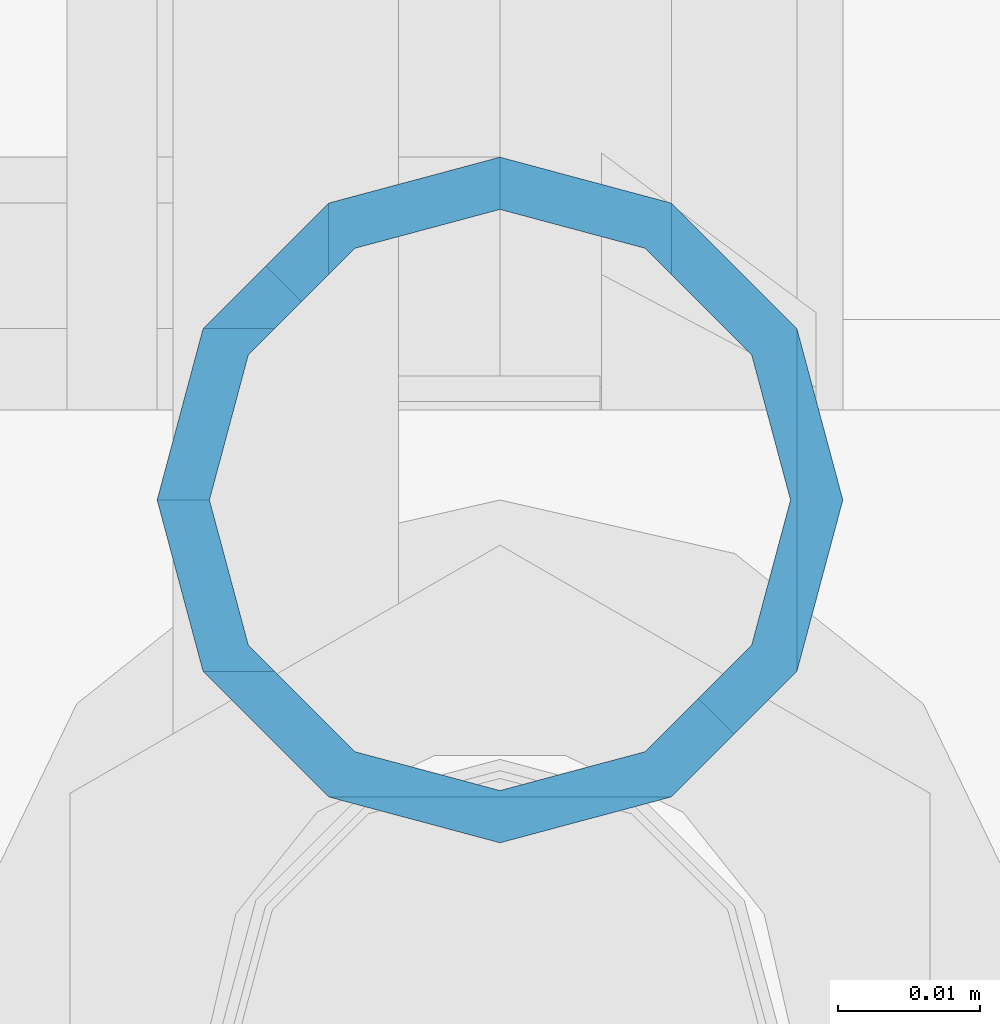
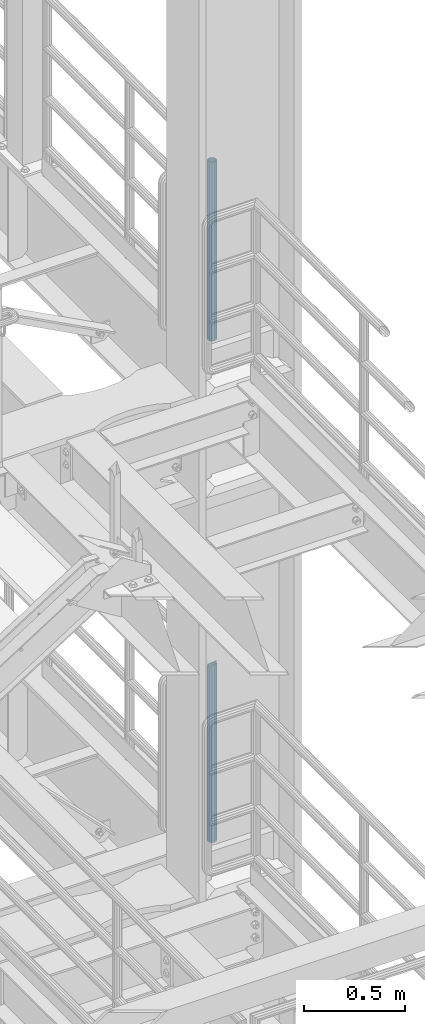
# One storey, part 663 of 1876: 2 columns, 2 elements without a shape of their own.
"""IFC2X3 building model written with IfcOpenShell, lengths in millimetres."""

from ifc_helpers import new_model, si_unit, frame, origin_with_axes, place, context, subcontext, project, spatial, faceted_brep, material, type_object, element, aggregate, save


model = new_model("IFC2X3")

# Units and contexts
model_context = context("Model", 3, precision=1e-05, world=origin_with_axes())
body_context = subcontext(model_context, "Body", "Model", "MODEL_VIEW")
ifc_project = project(units=[si_unit("LENGTHUNIT", "METRE", prefix="MILLI"), si_unit("AREAUNIT", "SQUARE_METRE"), si_unit("VOLUMEUNIT", "CUBIC_METRE"), si_unit("MASSUNIT", "GRAM", prefix="KILO"), si_unit("TIMEUNIT", "SECOND"), si_unit("PLANEANGLEUNIT", "RADIAN"), si_unit("SOLIDANGLEUNIT", "STERADIAN"), si_unit("THERMODYNAMICTEMPERATUREUNIT", "DEGREE_CELSIUS"), si_unit("LUMINOUSINTENSITYUNIT", "LUMEN")], contexts=[model_context])

# Site, building, storey
site_placement = place(None, origin_with_axes())
site = spatial("IfcSite", under=ifc_project, at=site_placement, CompositionType="ELEMENT")
building_placement = place(site_placement, origin_with_axes())
building = spatial("IfcBuilding", under=site, at=building_placement, Name="Undefined", CompositionType="ELEMENT")
storey_placement = place(building_placement, origin_with_axes())
storey = spatial("IfcBuildingStorey", under=building, at=storey_placement, Name="Undefined", CompositionType="ELEMENT", Elevation=0.0)

# Assembly, column
assembly_1_placement = place(storey_placement, origin_with_axes())
assembly_1 = element("IfcElementAssembly", 1, at=assembly_1_placement, inside=storey, Name="RAIL", AssemblyPlace="NOTDEFINED", PredefinedType="RIGID_FRAME")
ifc_material = material()
column_type = type_object("IfcColumnType", Name="PIPE1-1/2SCH40", PredefinedType="NOTDEFINED")
column_1_placement = place(assembly_1_placement, frame((7620.0, -4356.1, 8153.4), z_axis=(0.0, 1.0, 0.0), x_axis=(0.0, 0.0, 1.0)))
column_1 = element("IfcColumn", 2, at=column_1_placement, type_object=column_type, material=ifc_material, Name="POST", ObjectType="PIPE1-1/2SCH40", context=body_context, shape_type="Brep", body=[
    faceted_brep([(0.0, -20.4469999999999, 0.0), (0.0, -17.7076214311803, 10.2235000000001), (1076.325, -17.7076214311801, 10.2235000000001), (1076.325, -20.4469999999999, 0.0), (0.0, -10.2235000000001, 17.7076214311801), (1076.325, -10.2235000000001, 17.7076214311801), (-1.45519152283669e-11, 0.0, 20.4470000000001), (1076.325, 0.0, 20.4470000000001), (0.0, 10.2235000000001, 17.7076214311801), (1076.325, 10.2235000000001, 17.7076214311801), (0.0, 17.7076214311803, 10.2235000000001), (1076.325, 17.7076214311801, 10.2235000000001), (0.0, 20.4469999999999, 0.0), (1076.325, 20.4469999999999, 0.0), (0.0, 17.7076214311803, -10.2235000000001), (1076.325, 17.7076214311801, -10.2235000000001), (0.0, 10.2235000000001, -17.7076214311801), (1076.325, 10.2235000000001, -17.7076214311801), (-1.45519152283669e-11, 0.0, -20.4470000000001), (1076.325, 0.0, -20.4470000000001), (0.0, -10.2235000000001, -17.7076214311801), (1076.325, -10.2235000000001, -17.7076214311801), (0.0, -17.7076214311803, -10.2235000000001), (1076.325, -17.7076214311801, -10.2235000000001), (0.0, -24.1299999999992, 0.0), (0.0, -20.8971929933184, -12.0649999999996), (1076.325, -20.8971929933186, -12.0649999999996), (1076.325, -24.1300000000001, 0.0), (0.0, -12.0650000000001, -20.8971929933186), (1076.325, -12.0649999999996, -20.8971929933186), (-1.45519152283669e-11, 0.0, -24.130000000001), (1076.325, 0.0, -24.1300000000001), (0.0, 12.0650000000001, -20.8971929933186), (1076.325, 12.0649999999996, -20.8971929933186), (0.0, 20.8971929933184, -12.0649999999996), (1076.325, 20.8971929933186, -12.0649999999996), (0.0, 24.1299999999992, 0.0), (1076.325, 24.1300000000001, 0.0), (0.0, 20.8971929933184, 12.0649999999996), (1076.325, 20.8971929933186, 12.0649999999996), (0.0, 12.0650000000001, 20.8971929933186), (1076.325, 12.0649999999996, 20.8971929933186), (-1.45519152283669e-11, 0.0, 24.130000000001), (1076.325, 0.0, 24.1300000000001), (0.0, -12.0650000000001, 20.8971929933186), (1076.325, -12.0649999999996, 20.8971929933186), (0.0, -20.8971929933184, 12.0649999999996), (1076.325, -20.8971929933186, 12.0649999999996)], [[[0, 1, 2, 3]], [[1, 4, 5, 2]], [[4, 6, 7, 5]], [[6, 8, 9, 7]], [[8, 10, 11, 9]], [[10, 12, 13, 11]], [[12, 14, 15, 13]], [[14, 16, 17, 15]], [[16, 18, 19, 17]], [[18, 20, 21, 19]], [[20, 22, 23, 21]], [[22, 0, 3, 23]], [[24, 25, 26, 27]], [[25, 28, 29, 26]], [[28, 30, 31, 29]], [[30, 32, 33, 31]], [[32, 34, 35, 33]], [[34, 36, 37, 35]], [[36, 38, 39, 37]], [[38, 40, 41, 39]], [[40, 42, 43, 41]], [[42, 44, 45, 43]], [[44, 46, 47, 45]], [[46, 24, 27, 47]], [[29, 31, 33, 35, 37, 39, 41, 43, 45, 47, 27, 26], [5, 7, 9, 11, 13, 15, 17, 19, 21, 23, 3, 2]], [[46, 44, 42, 40, 38, 36, 34, 32, 30, 28, 25, 24], [22, 20, 18, 16, 14, 12, 10, 8, 6, 4, 1, 0]]]),
])
aggregate(assembly_1, [column_1])

assembly_2_placement = place(storey_placement, origin_with_axes())
assembly_2 = element("IfcElementAssembly", 3, at=assembly_2_placement, inside=storey, Name="RAIL", AssemblyPlace="NOTDEFINED", PredefinedType="RIGID_FRAME")
column_2_placement = place(assembly_2_placement, frame((7620.0, -4356.10000000001, 5130.8), z_axis=(0.0, 1.0, 0.0), x_axis=(0.0, 0.0, 1.0)))
column_2 = element("IfcColumn", 4, at=column_2_placement, type_object=column_type, material=ifc_material, Name="POST", ObjectType="PIPE1-1/2SCH40", context=body_context, shape_type="Brep", body=[
    faceted_brep([(1076.325, 0.0, -24.1300000000001), (1064.26, 12.065, -20.8971929933186), (1064.26, -12.0650000000001, -20.8971929933186), (1059.84389372908, 16.4810867391852, -16.481106254133), (1057.32835795174, 13.9655509593595, -13.9655704718216), (1061.07042843786, 10.2235000000001, -17.7076214311801), (1063.80980700668, 0.0, -20.4470000000001), (1061.07042843786, -10.2235000000001, -17.7076214311801), (1055.42780700668, -15.8661214311742, -12.065000000006), (1055.42780700668, -20.8971929933184, -12.0649999999996), (1054.93437856882, -17.7076214311801, -10.2235000000001), (1052.195, -20.4470000000001, 0.0), (1052.195, -24.1300000000001, 0.0), (1054.93437856882, -17.7076214311801, 10.2235000000001), (1055.42780700668, -15.8661214311869, 12.0649999999932), (1055.42780700668, -20.8971929933184, 12.0649999999996), (1057.32837749183, -13.9655704718189, 13.9655509593613), (1059.84391327663, -16.4811062541312, 16.481086739188), (1055.42780700668, -12.0650000000001, 15.8661214311805), (1055.42780700668, -12.0650000000001, 20.8971929933186), (1054.93437856882, -10.2235000000001, 17.7076214311801), (1052.195, 0.0, 20.4470000000001), (1052.195, 0.0, 24.1300000000001), (1054.93437856882, 10.2235000000001, 17.7076214311801), (1055.42780700668, 12.0650000000001, 15.8661214311805), (1055.42780700668, 12.0650000000001, 20.8971929933186), (1076.325, 24.1300000000001, 0.0), (1064.26, 20.8971929933184, 12.0649999999996), (1064.25999999999, 20.8971929933186, -12.0649999999996), (1061.07042843786, 17.7076214311803, 10.2235000000001), (1063.80980700668, 20.4469999999999, 0.0), (1061.07042843786, 17.7076214311803, -10.2235000000001), (0.0, -20.8971929933184, -12.0649999999996), (0.0, -12.0650000000001, -20.8971929933186), (-1.45519152283669e-11, 0.0, -24.130000000001), (0.0, 12.0650000000001, -20.8971929933186), (0.0, 20.8971929933184, -12.0649999999996), (0.0, 24.1299999999992, 0.0), (0.0, -20.8971929933184, 12.0649999999996), (0.0, -24.1299999999992, 0.0), (0.0, -12.0650000000001, 20.8971929933186), (-1.45519152283669e-11, 0.0, 24.130000000001), (0.0, 12.0650000000001, 20.8971929933186), (0.0, 20.8971929933184, 12.0649999999996), (0.0, -17.7076214311803, -10.2235000000001), (0.0, -10.2235000000001, -17.7076214311801), (-1.45519152283669e-11, 0.0, -20.4470000000001), (0.0, 10.2235000000001, -17.7076214311801), (0.0, 17.7076214311803, -10.2235000000001), (0.0, 20.4469999999999, 0.0), (0.0, 17.7076214311803, 10.2235000000001), (0.0, 10.2235000000001, 17.7076214311801), (-1.45519152283669e-11, 0.0, 20.4470000000001), (0.0, -10.2235000000001, 17.7076214311801), (0.0, -17.7076214311803, 10.2235000000001), (0.0, -20.4469999999999, 0.0)], [[[0, 1, 2]], [[2, 1, 3, 4, 5, 6, 7, 8, 9]], [[9, 8, 10, 11, 12]], [[12, 11, 13, 14, 15]], [[15, 14, 16, 17]], [[17, 16, 18, 19]], [[19, 18, 20, 21, 22]], [[22, 21, 23, 24, 25]], [[26, 27, 28]], [[25, 24, 29, 30, 31, 4, 3, 28, 27]], [[32, 33, 2, 9]], [[33, 34, 0, 2]], [[34, 35, 1, 0]], [[1, 35, 36, 28, 3]], [[36, 37, 26, 28]], [[38, 39, 12, 15]], [[40, 38, 15, 17, 19]], [[41, 40, 19, 22]], [[42, 41, 22, 25]], [[43, 42, 25, 27]], [[37, 43, 27, 26]], [[39, 32, 9, 12]], [[38, 40, 41, 42, 43, 37, 36, 35, 34, 33, 32, 39], [44, 45, 46, 47, 48, 49, 50, 51, 52, 53, 54, 55]], [[50, 49, 30, 29]], [[23, 51, 50, 29, 24]], [[52, 51, 23, 21]], [[53, 52, 21, 20]], [[13, 54, 53, 20, 18, 16, 14]], [[55, 54, 13, 11]], [[44, 55, 11, 10]], [[45, 44, 10, 8, 7]], [[46, 45, 7, 6]], [[47, 46, 6, 5]], [[48, 47, 5, 4, 31]], [[49, 48, 31, 30]]]),
])
aggregate(assembly_2, [column_2])

save(model, "model.ifc")
